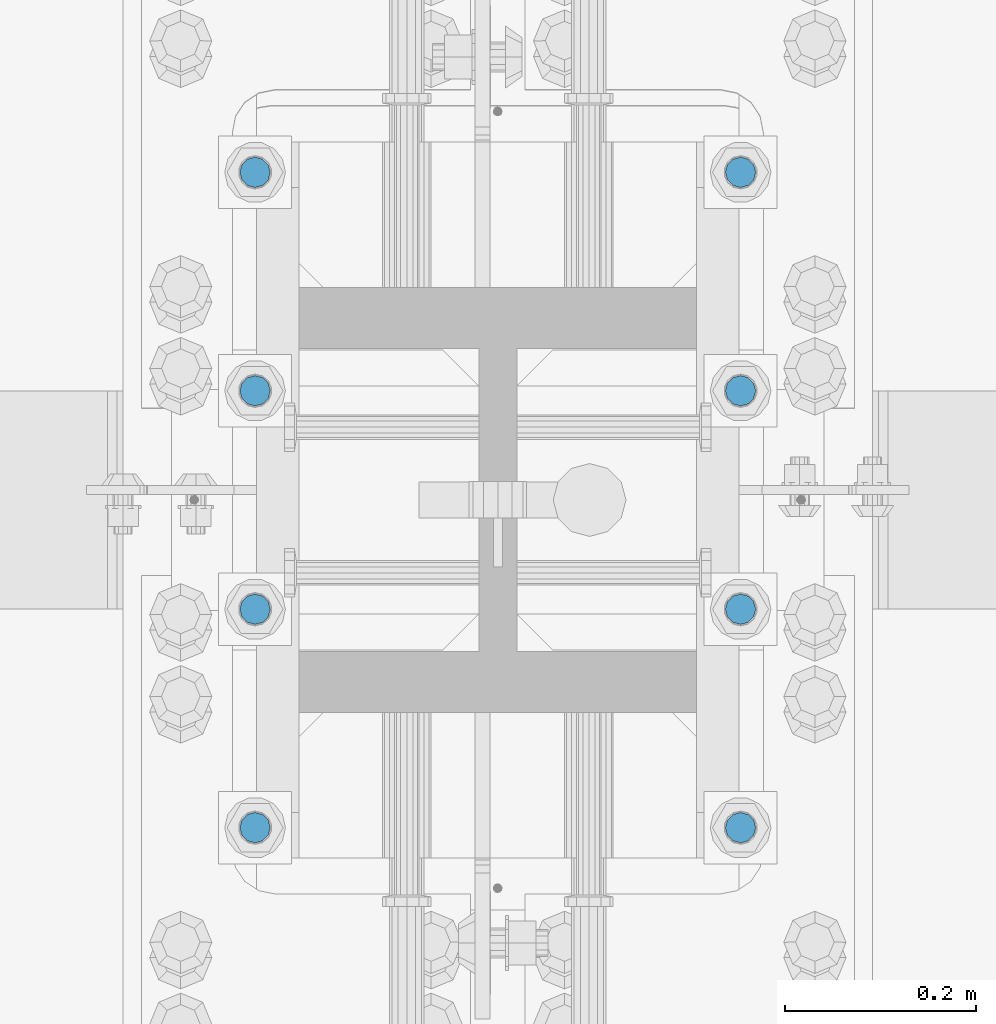
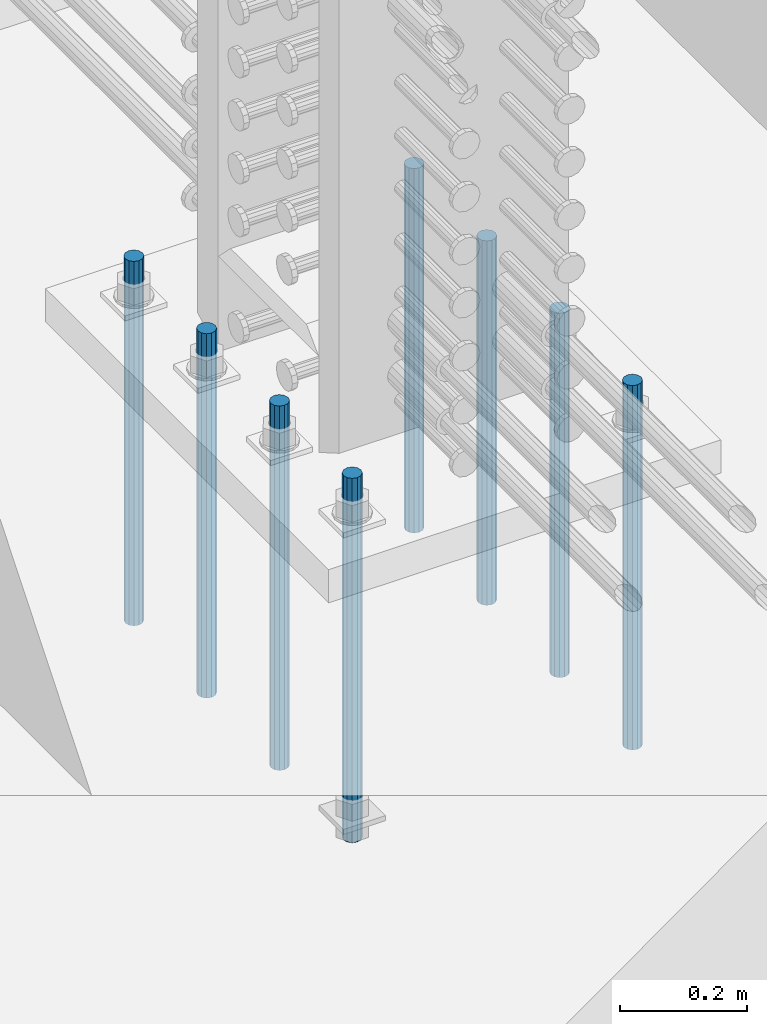
# One storey, part 938 of 1763: 8 columns, 1 element without a shape of its own.
"""IFC2X3 building model written with IfcOpenShell, lengths in millimetres."""

from ifc_helpers import new_model, si_unit, frame, origin_with_axes, place, context, subcontext, project, spatial, faceted_brep, material, type_object, element, aggregate, save


model = new_model("IFC2X3")

# Units and contexts
model_context = context("Model", 3, precision=1e-05, world=origin_with_axes())
body_context = subcontext(model_context, "Body", "Model", "MODEL_VIEW")
ifc_project = project(units=[si_unit("LENGTHUNIT", "METRE", prefix="MILLI"), si_unit("AREAUNIT", "SQUARE_METRE"), si_unit("VOLUMEUNIT", "CUBIC_METRE"), si_unit("MASSUNIT", "GRAM", prefix="KILO"), si_unit("TIMEUNIT", "SECOND"), si_unit("PLANEANGLEUNIT", "RADIAN"), si_unit("SOLIDANGLEUNIT", "STERADIAN"), si_unit("THERMODYNAMICTEMPERATUREUNIT", "DEGREE_CELSIUS"), si_unit("LUMINOUSINTENSITYUNIT", "LUMEN")], contexts=[model_context])

# Site, building, storey
site_placement = place(None, origin_with_axes())
site = spatial("IfcSite", under=ifc_project, at=site_placement, CompositionType="ELEMENT")
building_placement = place(site_placement, origin_with_axes())
building = spatial("IfcBuilding", under=site, at=building_placement, Name="Undefined", CompositionType="ELEMENT")
storey_placement = place(building_placement, origin_with_axes())
storey = spatial("IfcBuildingStorey", under=building, at=storey_placement, Name="Undefined", CompositionType="ELEMENT", Elevation=0.0)

# Assembly, columns
assembly_placement = place(storey_placement, origin_with_axes())
assembly = element("IfcElementAssembly", 1, at=assembly_placement, inside=storey, Name="TEMPLATE", AssemblyPlace="NOTDEFINED", PredefinedType="RIGID_FRAME")
ifc_material = material()
column_type = type_object("IfcColumnType", PredefinedType="NOTDEFINED")
column_1_placement = place(assembly_placement, frame((-24281.8372736984, 114.299999999998, 4000.5), z_axis=(0.0, -1.0, 0.0), x_axis=(0.0, 0.0, -1.0)))
column_1 = element("IfcColumn", 2, at=column_1_placement, type_object=column_type, material=ifc_material, Name="ALL THREADED ROD", context=body_context, shape_type="Brep", body=[
    faceted_brep([(0.0, -15.875, 0.0), (0.0, -13.7481532850798, -7.9375), (698.499, -13.7481532850798, -7.9375), (698.499, -15.875, 0.0), (0.0, -7.9375, -13.748153285078), (698.499, -7.9375, -13.748153285078), (4.91792532185561e-12, 0.0, -15.875), (698.499, 0.0, -15.875), (0.0, 7.9375, -13.748153285078), (698.499, 7.9375, -13.748153285078), (0.0, 13.7481532850798, -7.9375), (698.499, 13.7481532850798, -7.9375), (0.0, 15.875, 0.0), (698.499, 15.875, 0.0), (0.0, 13.7481532850798, 7.9375), (698.499, 13.7481532850798, 7.9375), (0.0, 7.9375, 13.748153285078), (698.499, 7.9375, 13.748153285078), (-1.64518337079051e-12, 0.0, 15.875), (698.499, 0.0, 15.875), (0.0, -7.9375, 13.748153285078), (698.499, -7.9375, 13.748153285078), (0.0, -13.7481532850798, 7.9375), (698.499, -13.7481532850798, 7.9375)], [[[0, 1, 2, 3]], [[1, 4, 5, 2]], [[4, 6, 7, 5]], [[6, 8, 9, 7]], [[8, 10, 11, 9]], [[10, 12, 13, 11]], [[12, 14, 15, 13]], [[14, 16, 17, 15]], [[16, 18, 19, 17]], [[18, 20, 21, 19]], [[20, 22, 23, 21]], [[22, 0, 3, 23]], [[5, 7, 9, 11, 13, 15, 17, 19, 21, 23, 3, 2]], [[22, 20, 18, 16, 14, 12, 10, 8, 6, 4, 1, 0]]]),
])
column_2_placement = place(assembly_placement, frame((-23773.8372736984, 114.299999999998, 4000.5), z_axis=(0.0, 1.0, 0.0), x_axis=(0.0, 0.0, -1.0)))
column_2 = element("IfcColumn", 3, at=column_2_placement, type_object=column_type, material=ifc_material, Name="ALL THREADED ROD", context=body_context, shape_type="Brep", body=[
    faceted_brep([(0.0, -15.875, 0.0), (0.0, -13.7481532850798, -7.9375), (698.499, -13.7481532850798, -7.9375), (698.499, -15.875, 0.0), (0.0, -7.9375, -13.748153285078), (698.499, -7.9375, -13.748153285078), (4.91792532185561e-12, 0.0, -15.875), (698.499, 0.0, -15.875), (0.0, 7.9375, -13.748153285078), (698.499, 7.9375, -13.748153285078), (0.0, 13.7481532850798, -7.9375), (698.499, 13.7481532850798, -7.9375), (0.0, 15.875, 0.0), (698.499, 15.875, 0.0), (0.0, 13.7481532850798, 7.9375), (698.499, 13.7481532850798, 7.9375), (0.0, 7.9375, 13.748153285078), (698.499, 7.9375, 13.748153285078), (-1.64518337079051e-12, 0.0, 15.875), (698.499, 0.0, 15.875), (0.0, -7.9375, 13.748153285078), (698.499, -7.9375, 13.748153285078), (0.0, -13.7481532850798, 7.9375), (698.499, -13.7481532850798, 7.9375)], [[[0, 1, 2, 3]], [[1, 4, 5, 2]], [[4, 6, 7, 5]], [[6, 8, 9, 7]], [[8, 10, 11, 9]], [[10, 12, 13, 11]], [[12, 14, 15, 13]], [[14, 16, 17, 15]], [[16, 18, 19, 17]], [[18, 20, 21, 19]], [[20, 22, 23, 21]], [[22, 0, 3, 23]], [[5, 7, 9, 11, 13, 15, 17, 19, 21, 23, 3, 2]], [[22, 20, 18, 16, 14, 12, 10, 8, 6, 4, 1, 0]]]),
])
column_3_placement = place(assembly_placement, frame((-24281.8372736984, 342.899999999998, 4000.5), z_axis=(0.0, -1.0, 0.0), x_axis=(0.0, 0.0, -1.0)))
column_3 = element("IfcColumn", 4, at=column_3_placement, type_object=column_type, material=ifc_material, Name="ALL THREADED ROD", context=body_context, shape_type="Brep", body=[
    faceted_brep([(0.0, -15.875, 0.0), (0.0, -13.7481532850798, -7.9375), (698.499, -13.7481532850798, -7.9375), (698.499, -15.875, 0.0), (0.0, -7.9375, -13.748153285078), (698.499, -7.9375, -13.748153285078), (4.91792532185561e-12, 0.0, -15.875), (698.499, 0.0, -15.875), (0.0, 7.9375, -13.748153285078), (698.499, 7.9375, -13.748153285078), (0.0, 13.7481532850798, -7.9375), (698.499, 13.7481532850798, -7.9375), (0.0, 15.875, 0.0), (698.499, 15.875, 0.0), (0.0, 13.7481532850798, 7.9375), (698.499, 13.7481532850798, 7.9375), (0.0, 7.9375, 13.748153285078), (698.499, 7.9375, 13.748153285078), (-1.64518337079051e-12, 0.0, 15.875), (698.499, 0.0, 15.875), (0.0, -7.9375, 13.748153285078), (698.499, -7.9375, 13.748153285078), (0.0, -13.7481532850798, 7.9375), (698.499, -13.7481532850798, 7.9375)], [[[0, 1, 2, 3]], [[1, 4, 5, 2]], [[4, 6, 7, 5]], [[6, 8, 9, 7]], [[8, 10, 11, 9]], [[10, 12, 13, 11]], [[12, 14, 15, 13]], [[14, 16, 17, 15]], [[16, 18, 19, 17]], [[18, 20, 21, 19]], [[20, 22, 23, 21]], [[22, 0, 3, 23]], [[5, 7, 9, 11, 13, 15, 17, 19, 21, 23, 3, 2]], [[22, 20, 18, 16, 14, 12, 10, 8, 6, 4, 1, 0]]]),
])
column_4_placement = place(assembly_placement, frame((-23773.8372736984, 342.899999999998, 4000.5), z_axis=(0.0, 1.0, 0.0), x_axis=(0.0, 0.0, -1.0)))
column_4 = element("IfcColumn", 5, at=column_4_placement, type_object=column_type, material=ifc_material, Name="ALL THREADED ROD", context=body_context, shape_type="Brep", body=[
    faceted_brep([(0.0, -15.875, 0.0), (0.0, -13.7481532850798, -7.9375), (698.499, -13.7481532850798, -7.9375), (698.499, -15.875, 0.0), (0.0, -7.9375, -13.748153285078), (698.499, -7.9375, -13.748153285078), (4.91792532185561e-12, 0.0, -15.875), (698.499, 0.0, -15.875), (0.0, 7.9375, -13.748153285078), (698.499, 7.9375, -13.748153285078), (0.0, 13.7481532850798, -7.9375), (698.499, 13.7481532850798, -7.9375), (0.0, 15.875, 0.0), (698.499, 15.875, 0.0), (0.0, 13.7481532850798, 7.9375), (698.499, 13.7481532850798, 7.9375), (0.0, 7.9375, 13.748153285078), (698.499, 7.9375, 13.748153285078), (-1.64518337079051e-12, 0.0, 15.875), (698.499, 0.0, 15.875), (0.0, -7.9375, 13.748153285078), (698.499, -7.9375, 13.748153285078), (0.0, -13.7481532850798, 7.9375), (698.499, -13.7481532850798, 7.9375)], [[[0, 1, 2, 3]], [[1, 4, 5, 2]], [[4, 6, 7, 5]], [[6, 8, 9, 7]], [[8, 10, 11, 9]], [[10, 12, 13, 11]], [[12, 14, 15, 13]], [[14, 16, 17, 15]], [[16, 18, 19, 17]], [[18, 20, 21, 19]], [[20, 22, 23, 21]], [[22, 0, 3, 23]], [[5, 7, 9, 11, 13, 15, 17, 19, 21, 23, 3, 2]], [[22, 20, 18, 16, 14, 12, 10, 8, 6, 4, 1, 0]]]),
])
column_5_placement = place(assembly_placement, frame((-24281.8372736984, 571.499999999998, 4000.5), z_axis=(0.0, -1.0, 0.0), x_axis=(0.0, 0.0, -1.0)))
column_5 = element("IfcColumn", 6, at=column_5_placement, type_object=column_type, material=ifc_material, Name="ALL THREADED ROD", context=body_context, shape_type="Brep", body=[
    faceted_brep([(0.0, -15.875, 0.0), (0.0, -13.7481532850798, -7.9375), (698.499, -13.7481532850798, -7.9375), (698.499, -15.875, 0.0), (0.0, -7.9375, -13.748153285078), (698.499, -7.9375, -13.748153285078), (4.91792532185561e-12, 0.0, -15.875), (698.499, 0.0, -15.875), (0.0, 7.9375, -13.748153285078), (698.499, 7.9375, -13.748153285078), (0.0, 13.7481532850798, -7.9375), (698.499, 13.7481532850798, -7.9375), (0.0, 15.875, 0.0), (698.499, 15.875, 0.0), (0.0, 13.7481532850798, 7.9375), (698.499, 13.7481532850798, 7.9375), (0.0, 7.9375, 13.748153285078), (698.499, 7.9375, 13.748153285078), (-1.64518337079051e-12, 0.0, 15.875), (698.499, 0.0, 15.875), (0.0, -7.9375, 13.748153285078), (698.499, -7.9375, 13.748153285078), (0.0, -13.7481532850798, 7.9375), (698.499, -13.7481532850798, 7.9375)], [[[0, 1, 2, 3]], [[1, 4, 5, 2]], [[4, 6, 7, 5]], [[6, 8, 9, 7]], [[8, 10, 11, 9]], [[10, 12, 13, 11]], [[12, 14, 15, 13]], [[14, 16, 17, 15]], [[16, 18, 19, 17]], [[18, 20, 21, 19]], [[20, 22, 23, 21]], [[22, 0, 3, 23]], [[5, 7, 9, 11, 13, 15, 17, 19, 21, 23, 3, 2]], [[22, 20, 18, 16, 14, 12, 10, 8, 6, 4, 1, 0]]]),
])
column_6_placement = place(assembly_placement, frame((-23773.8372736984, 571.499999999998, 4000.5), z_axis=(0.0, 1.0, 0.0), x_axis=(0.0, 0.0, -1.0)))
column_6 = element("IfcColumn", 7, at=column_6_placement, type_object=column_type, material=ifc_material, Name="ALL THREADED ROD", context=body_context, shape_type="Brep", body=[
    faceted_brep([(0.0, -15.875, 0.0), (0.0, -13.7481532850798, -7.9375), (698.499, -13.7481532850798, -7.9375), (698.499, -15.875, 0.0), (0.0, -7.9375, -13.748153285078), (698.499, -7.9375, -13.748153285078), (4.91792532185561e-12, 0.0, -15.875), (698.499, 0.0, -15.875), (0.0, 7.9375, -13.748153285078), (698.499, 7.9375, -13.748153285078), (0.0, 13.7481532850798, -7.9375), (698.499, 13.7481532850798, -7.9375), (0.0, 15.875, 0.0), (698.499, 15.875, 0.0), (0.0, 13.7481532850798, 7.9375), (698.499, 13.7481532850798, 7.9375), (0.0, 7.9375, 13.748153285078), (698.499, 7.9375, 13.748153285078), (-1.64518337079051e-12, 0.0, 15.875), (698.499, 0.0, 15.875), (0.0, -7.9375, 13.748153285078), (698.499, -7.9375, 13.748153285078), (0.0, -13.7481532850798, 7.9375), (698.499, -13.7481532850798, 7.9375)], [[[0, 1, 2, 3]], [[1, 4, 5, 2]], [[4, 6, 7, 5]], [[6, 8, 9, 7]], [[8, 10, 11, 9]], [[10, 12, 13, 11]], [[12, 14, 15, 13]], [[14, 16, 17, 15]], [[16, 18, 19, 17]], [[18, 20, 21, 19]], [[20, 22, 23, 21]], [[22, 0, 3, 23]], [[5, 7, 9, 11, 13, 15, 17, 19, 21, 23, 3, 2]], [[22, 20, 18, 16, 14, 12, 10, 8, 6, 4, 1, 0]]]),
])
column_7_placement = place(assembly_placement, frame((-24281.8372736984, 800.099999999998, 4000.5), z_axis=(0.0, -1.0, 0.0), x_axis=(0.0, 0.0, -1.0)))
column_7 = element("IfcColumn", 8, at=column_7_placement, type_object=column_type, material=ifc_material, Name="ALL THREADED ROD", context=body_context, shape_type="Brep", body=[
    faceted_brep([(0.0, -15.875, 0.0), (0.0, -13.7481532850798, -7.9375), (698.499, -13.7481532850798, -7.9375), (698.499, -15.875, 0.0), (0.0, -7.9375, -13.748153285078), (698.499, -7.9375, -13.748153285078), (4.91792532185561e-12, 0.0, -15.875), (698.499, 0.0, -15.875), (0.0, 7.9375, -13.748153285078), (698.499, 7.9375, -13.748153285078), (0.0, 13.7481532850798, -7.9375), (698.499, 13.7481532850798, -7.9375), (0.0, 15.875, 0.0), (698.499, 15.875, 0.0), (0.0, 13.7481532850798, 7.9375), (698.499, 13.7481532850798, 7.9375), (0.0, 7.9375, 13.748153285078), (698.499, 7.9375, 13.748153285078), (-1.64518337079051e-12, 0.0, 15.875), (698.499, 0.0, 15.875), (0.0, -7.9375, 13.748153285078), (698.499, -7.9375, 13.748153285078), (0.0, -13.7481532850798, 7.9375), (698.499, -13.7481532850798, 7.9375)], [[[0, 1, 2, 3]], [[1, 4, 5, 2]], [[4, 6, 7, 5]], [[6, 8, 9, 7]], [[8, 10, 11, 9]], [[10, 12, 13, 11]], [[12, 14, 15, 13]], [[14, 16, 17, 15]], [[16, 18, 19, 17]], [[18, 20, 21, 19]], [[20, 22, 23, 21]], [[22, 0, 3, 23]], [[5, 7, 9, 11, 13, 15, 17, 19, 21, 23, 3, 2]], [[22, 20, 18, 16, 14, 12, 10, 8, 6, 4, 1, 0]]]),
])
column_8_placement = place(assembly_placement, frame((-23773.8372736984, 800.099999999998, 4000.5), z_axis=(0.0, 1.0, 0.0), x_axis=(0.0, 0.0, -1.0)))
column_8 = element("IfcColumn", 9, at=column_8_placement, type_object=column_type, material=ifc_material, Name="ALL THREADED ROD", context=body_context, shape_type="Brep", body=[
    faceted_brep([(0.0, -15.875, 0.0), (0.0, -13.7481532850798, -7.9375), (698.499, -13.7481532850798, -7.9375), (698.499, -15.875, 0.0), (0.0, -7.9375, -13.748153285078), (698.499, -7.9375, -13.748153285078), (4.91792532185561e-12, 0.0, -15.875), (698.499, 0.0, -15.875), (0.0, 7.9375, -13.748153285078), (698.499, 7.9375, -13.748153285078), (0.0, 13.7481532850798, -7.9375), (698.499, 13.7481532850798, -7.9375), (0.0, 15.875, 0.0), (698.499, 15.875, 0.0), (0.0, 13.7481532850798, 7.9375), (698.499, 13.7481532850798, 7.9375), (0.0, 7.9375, 13.748153285078), (698.499, 7.9375, 13.748153285078), (-1.64518337079051e-12, 0.0, 15.875), (698.499, 0.0, 15.875), (0.0, -7.9375, 13.748153285078), (698.499, -7.9375, 13.748153285078), (0.0, -13.7481532850798, 7.9375), (698.499, -13.7481532850798, 7.9375)], [[[0, 1, 2, 3]], [[1, 4, 5, 2]], [[4, 6, 7, 5]], [[6, 8, 9, 7]], [[8, 10, 11, 9]], [[10, 12, 13, 11]], [[12, 14, 15, 13]], [[14, 16, 17, 15]], [[16, 18, 19, 17]], [[18, 20, 21, 19]], [[20, 22, 23, 21]], [[22, 0, 3, 23]], [[5, 7, 9, 11, 13, 15, 17, 19, 21, 23, 3, 2]], [[22, 20, 18, 16, 14, 12, 10, 8, 6, 4, 1, 0]]]),
])
aggregate(assembly, [column_1, column_2, column_3, column_4, column_5, column_6, column_7, column_8])

save(model, "model.ifc")
